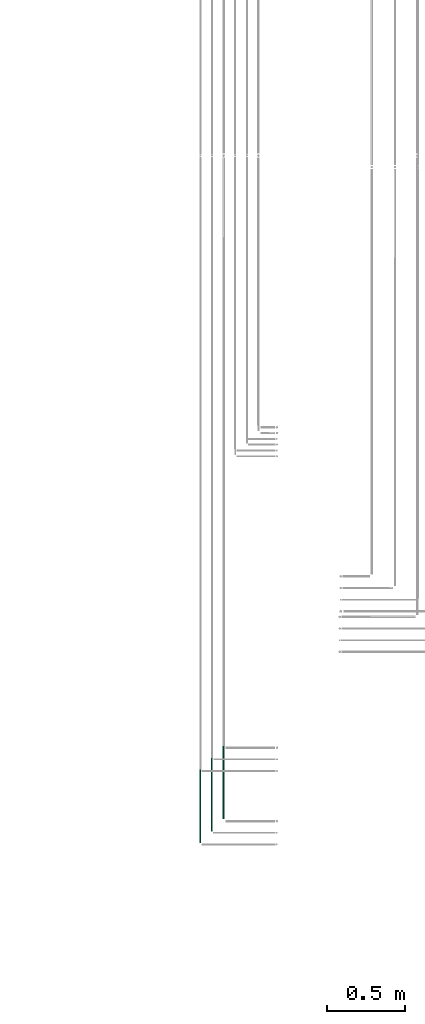
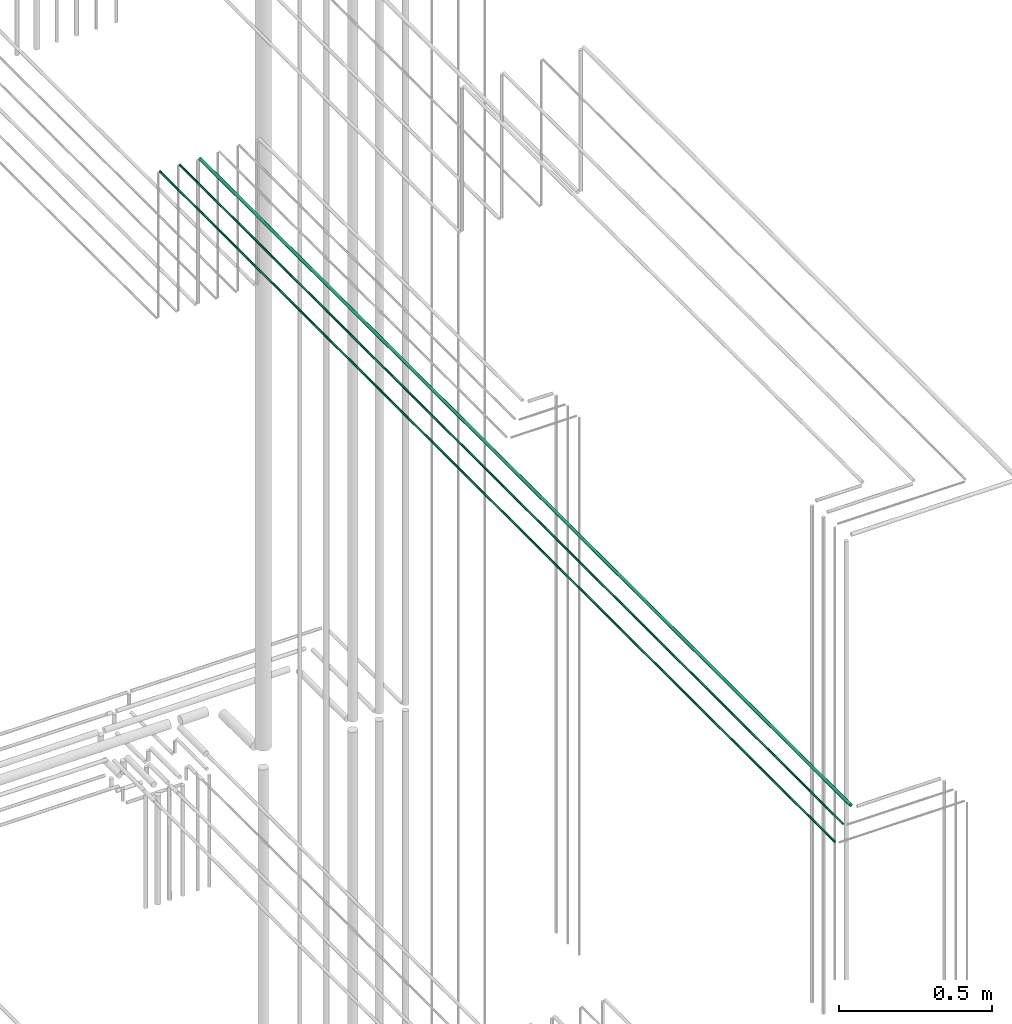
# One storey, part 73 of 331: 3 flow segments.
"""IFC2X3 building model written with IfcOpenShell, lengths in millimetres."""

from ifc_helpers import new_model, entity, si_unit, converted_unit, derived_unit, direction, frame, origin, origin_2d_with_axis, place, context, subcontext, project, spatial, circle, extrude, type_object, element, save


model = new_model("IFC2X3")

# Units and contexts
model_context = context("Model", 3, precision=0.01, world=origin(), true_north=direction((6.12303176911189e-17, 1.0)))
body_context = subcontext(model_context, "Body", "Model", "MODEL_VIEW")
ifc_project = project(units=[si_unit("LENGTHUNIT", "METRE", prefix="MILLI"), si_unit("AREAUNIT", "SQUARE_METRE"), si_unit("VOLUMEUNIT", "CUBIC_METRE"), converted_unit("PLANEANGLEUNIT", "DEGREE", entity("IfcRatioMeasure", 0.0174532925199433), si_unit("PLANEANGLEUNIT", "RADIAN"), dimensions=[0, 0, 0, 0, 0, 0, 0]), si_unit("MASSUNIT", "GRAM", prefix="KILO"), derived_unit("MASSDENSITYUNIT", [(si_unit("MASSUNIT", "GRAM", prefix="KILO"), 1), (si_unit("LENGTHUNIT", "METRE"), -3)]), derived_unit("MOMENTOFINERTIAUNIT", [(si_unit("LENGTHUNIT", "METRE"), 4)]), si_unit("TIMEUNIT", "SECOND"), si_unit("FREQUENCYUNIT", "HERTZ"), si_unit("THERMODYNAMICTEMPERATUREUNIT", "DEGREE_CELSIUS"), derived_unit("THERMALTRANSMITTANCEUNIT", [(si_unit("MASSUNIT", "GRAM", prefix="KILO"), 1), (si_unit("THERMODYNAMICTEMPERATUREUNIT", "KELVIN"), -1), (si_unit("TIMEUNIT", "SECOND"), -3)]), derived_unit("VOLUMETRICFLOWRATEUNIT", [(si_unit("LENGTHUNIT", "METRE"), 3), (si_unit("TIMEUNIT", "SECOND"), -1)]), derived_unit("MASSFLOWRATEUNIT", [(si_unit("MASSUNIT", "GRAM", prefix="KILO"), 1), (si_unit("TIMEUNIT", "SECOND"), -1)]), derived_unit("ROTATIONALFREQUENCYUNIT", [(si_unit("TIMEUNIT", "SECOND"), -1)]), si_unit("ELECTRICCURRENTUNIT", "AMPERE"), si_unit("ELECTRICVOLTAGEUNIT", "VOLT"), si_unit("POWERUNIT", "WATT"), si_unit("FORCEUNIT", "NEWTON", prefix="KILO"), si_unit("ILLUMINANCEUNIT", "LUX"), si_unit("LUMINOUSFLUXUNIT", "LUMEN"), si_unit("LUMINOUSINTENSITYUNIT", "CANDELA"), derived_unit("USERDEFINED", [(si_unit("MASSUNIT", "GRAM", prefix="KILO"), -1), (si_unit("LENGTHUNIT", "METRE"), -2), (si_unit("TIMEUNIT", "SECOND"), 3), (si_unit("LUMINOUSFLUXUNIT", "LUMEN"), 1)]), derived_unit("LINEARVELOCITYUNIT", [(si_unit("LENGTHUNIT", "METRE"), 1), (si_unit("TIMEUNIT", "SECOND"), -1)]), si_unit("PRESSUREUNIT", "PASCAL"), derived_unit("USERDEFINED", [(si_unit("LENGTHUNIT", "METRE"), -2), (si_unit("MASSUNIT", "GRAM", prefix="KILO"), 1), (si_unit("TIMEUNIT", "SECOND"), -2)]), derived_unit("LINEARFORCEUNIT", [(si_unit("MASSUNIT", "GRAM", prefix="KILO"), 1), (si_unit("LENGTHUNIT", "METRE"), 1), (si_unit("TIMEUNIT", "SECOND"), -2), (si_unit("LENGTHUNIT", "METRE"), -1)]), derived_unit("PLANARFORCEUNIT", [(si_unit("MASSUNIT", "GRAM", prefix="KILO"), 1), (si_unit("LENGTHUNIT", "METRE"), 1), (si_unit("TIMEUNIT", "SECOND"), -2), (si_unit("LENGTHUNIT", "METRE"), -2)])], contexts=[model_context])

# Site, building, storey
site_placement = place(None, frame((0.0, -0.00077364408347762, 0.0)))
site = spatial("IfcSite", under=ifc_project, at=site_placement, CompositionType="ELEMENT")
building_placement = place(site_placement, origin())
building = spatial("IfcBuilding", under=site, at=building_placement, CompositionType="ELEMENT")
storey_placement = place(building_placement, origin())
storey = spatial("IfcBuildingStorey", under=building, at=storey_placement, CompositionType="ELEMENT", Elevation=0.0)

# Flow segments
pipe_segment_type = type_object("IfcPipeSegmentType", PredefinedType="NOTDEFINED")
flow_segment_1_placement = place(storey_placement, frame((62012.4468045266, 1365.48876707963, 19042.4047277641)))
element("IfcFlowSegment", 1, at=flow_segment_1_placement, inside=storey, type_object=pipe_segment_type, context=body_context, shape_type="SweptSolid", body=[
    extrude(circle(Radius=6.0, at=origin_2d_with_axis()), frame((7.59527223591454, 0.0, 7.5952722359167), z_axis=(0.0, 1.0, 0.0), x_axis=(1.0, 0.0, 0.0)), (0.0, 0.0, 1.0), 4264.13179674766),
])
flow_segment_2_placement = place(storey_placement, frame((61939.4468045266, 1286.48876707963, 19044.4047277641)))
element("IfcFlowSegment", 2, at=flow_segment_2_placement, inside=storey, type_object=pipe_segment_type, context=body_context, shape_type="SweptSolid", body=[
    extrude(circle(Radius=4.0, at=origin_2d_with_axis()), frame((5.59527223591499, 0.0, 5.59527223591499), z_axis=(0.0, 1.0, 0.0), x_axis=(1.0, 0.0, 0.0)), (0.0, 0.0, 1.0), 4347.13179674766),
])
flow_segment_3_placement = place(storey_placement, frame((61864.4468045266, 1211.48876707963, 19044.4047277641)))
element("IfcFlowSegment", 3, at=flow_segment_3_placement, inside=storey, type_object=pipe_segment_type, context=body_context, shape_type="SweptSolid", body=[
    extrude(circle(Radius=4.0, at=origin_2d_with_axis()), frame((5.59527223591499, 0.0, 5.59527223591499), z_axis=(0.0, 1.0, 0.0), x_axis=(1.0, 0.0, 0.0)), (0.0, 0.0, 1.0), 4422.13179674766),
])

save(model, "model.ifc")
